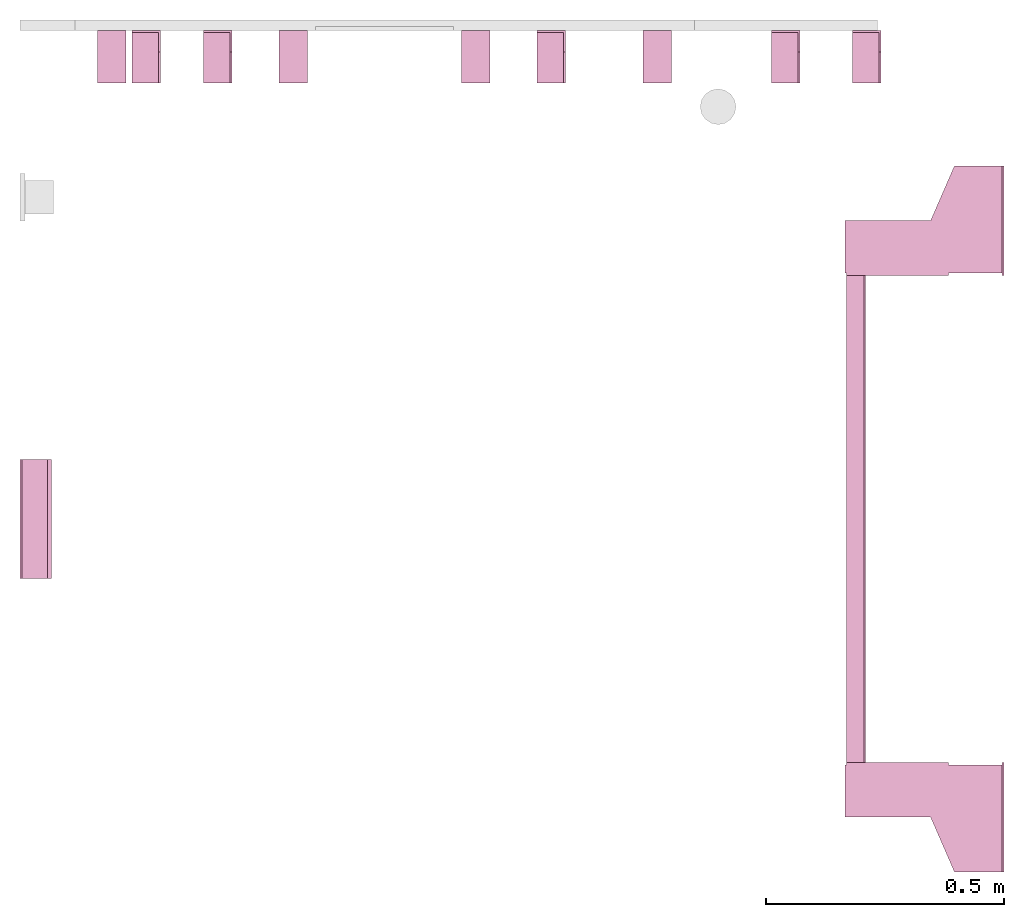
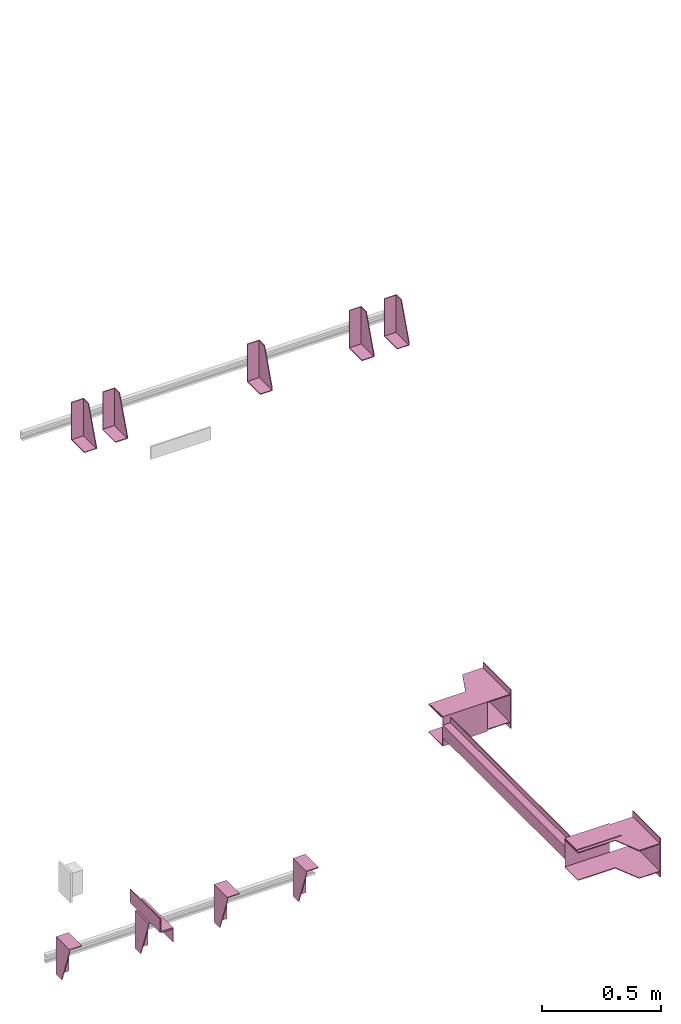
# One storey, part 3 of 3: 11 transport elements.
"""IFC4 building model written with IfcOpenShell, lengths in millimetres."""

from ifc_helpers import new_model, entity, si_unit, converted_unit, frame, origin_with_axes, place, context, subcontext, project, spatial, faceted_brep, element, save


model = new_model("IFC4")

# Units and contexts
context_of_model = context(None, 3, precision=0.01, world=origin_with_axes())
sub_context_1 = subcontext(context_of_model, None, None, "MODEL_VIEW")
sub_context_2 = subcontext(context_of_model, None, None, "MODEL_VIEW")
sub_context_3 = subcontext(context_of_model, None, None, "MODEL_VIEW")
sub_context_4 = subcontext(context_of_model, None, None, "MODEL_VIEW")
sub_context_5 = subcontext(context_of_model, None, None, "MODEL_VIEW")
sub_context_6 = subcontext(context_of_model, None, None, "MODEL_VIEW")
sub_context_7 = subcontext(context_of_model, None, None, "MODEL_VIEW")
sub_context_8 = subcontext(context_of_model, None, None, "MODEL_VIEW")
sub_context_9 = subcontext(context_of_model, None, None, "MODEL_VIEW")
sub_context_10 = subcontext(context_of_model, None, None, "MODEL_VIEW")
sub_context_11 = subcontext(context_of_model, None, None, "MODEL_VIEW")
ifc_project = project(units=[converted_unit("PLANEANGLEUNIT", "degree", entity("IfcPlaneAngleMeasure", 0.017453292519943), si_unit("PLANEANGLEUNIT", "RADIAN"), dimensions=[0, 0, 0, 0, 0, 0, 0]), si_unit("LENGTHUNIT", "METRE", prefix="MILLI"), si_unit("MASSUNIT", "GRAM", prefix="KILO"), converted_unit("TIMEUNIT", "year", entity("IfcTimeMeasure", 31557600.0), si_unit("TIMEUNIT", "SECOND"), dimensions=[0, 0, 1, 0, 0, 0, 0]), si_unit("THERMODYNAMICTEMPERATUREUNIT", "DEGREE_CELSIUS"), si_unit("AREAUNIT", "SQUARE_METRE"), si_unit("FORCEUNIT", "NEWTON"), si_unit("VOLUMEUNIT", "CUBIC_METRE"), si_unit("PRESSUREUNIT", "PASCAL"), si_unit("SOLIDANGLEUNIT", "STERADIAN")], contexts=[context_of_model])

# Site, building, storey
site = spatial("IfcSite", under=ifc_project)
building = spatial("IfcBuilding", under=site, Name="Document")
placement = place(None, origin_with_axes())
storey_placement = place(placement, frame((0.0, 0.0, -15980.0), z_axis=(0.0, 0.0, 1.0), x_axis=(1.0, 0.0, 0.0)))
storey = spatial("IfcBuildingStorey", under=building, at=storey_placement, Name="P5", Elevation=-15980.0)

# Transport elements
transport_element_1_placement = place(storey_placement, frame((2065.0, 1025.0, 780.0), z_axis=(0.0, 0.0, 1.0), x_axis=(0.0, 1.0, 0.0)))
element("IfcTransportElement", 1, at=transport_element_1_placement, inside=storey, PredefinedType="ELEVATOR", context=sub_context_1, shape_type="Brep", body=[
    faceted_brep([(-511.0, 291.0, -32.5), (-511.0, 294.0, -32.5), (-511.0, 294.0, -59.5), (-511.0, 291.0, -59.5), (511.0, 291.0, -32.5), (511.0, 291.0, -59.5), (511.0, 294.0, -59.5), (511.0, 294.0, -32.5)], [[[0, 1, 2, 3]], [[4, 5, 6, 7]], [[0, 3, 5, 4]], [[3, 2, 6, 5]], [[2, 1, 7, 6]], [[1, 0, 4, 7]]]),
    faceted_brep([(-611.0, 331.0, -72.5), (-514.0, 331.0, -72.5), (-514.0, 331.0, 72.5), (-611.0, 331.0, 72.5), (-611.0, 331.0, 75.5), (-511.0, 331.0, 75.5), (-511.0, 331.0, -75.5), (-611.0, 331.0, -75.5), (-511.0, 116.0, -75.5), (-511.0, 116.0, 75.5), (-611.0, 116.0, 75.5), (-611.0, 116.0, 72.5), (-514.0, 116.0, 72.5), (-514.0, 116.0, -72.5), (-611.0, 116.0, -72.5), (-611.0, 116.0, -75.5)], [[[0, 1, 2, 3, 4, 5, 6, 7]], [[8, 9, 10, 11, 12, 13, 14, 15]], [[15, 14, 0, 7]], [[13, 12, 2, 1]], [[5, 9, 8, 6]], [[11, 10, 4, 3]], [[6, 8, 15, 7]], [[14, 13, 1, 0]], [[2, 12, 11, 3]], [[10, 9, 5, 4]]]),
    faceted_brep([(-511.0, 291.0, 59.5), (-511.0, 294.0, 59.5), (-511.0, 294.0, 32.5), (-511.0, 291.0, 32.5), (511.0, 291.0, 59.5), (511.0, 291.0, 32.5), (511.0, 294.0, 32.5), (511.0, 294.0, 59.5)], [[[0, 1, 2, 3]], [[4, 5, 6, 7]], [[0, 3, 5, 4]], [[3, 2, 6, 5]], [[2, 1, 7, 6]], [[1, 0, 4, 7]]]),
    faceted_brep([(511.0, 331.0, 75.5), (611.0, 331.0, 75.5), (611.0, 331.0, 72.5), (514.0, 331.0, 72.5), (514.0, 331.0, -72.5), (611.0, 331.0, -72.5), (611.0, 331.0, -75.5), (511.0, 331.0, -75.5), (511.0, 116.0, -75.5), (611.0, 116.0, -75.5), (611.0, 116.0, -72.5), (514.0, 116.0, -72.5), (514.0, 116.0, 72.5), (611.0, 116.0, 72.5), (611.0, 116.0, 75.5), (511.0, 116.0, 75.5)], [[[0, 1, 2, 3, 4, 5, 6, 7]], [[8, 9, 10, 11, 12, 13, 14, 15]], [[8, 15, 0, 7]], [[3, 12, 11, 4]], [[5, 10, 9, 6]], [[1, 14, 13, 2]], [[6, 9, 8, 7]], [[11, 10, 5, 4]], [[15, 14, 1, 0]], [[2, 13, 12, 3]]]),
    faceted_brep([(-511.0, 331.0, 32.5), (511.0, 331.0, 32.5), (511.0, 331.0, -32.5), (-511.0, 331.0, -32.5), (511.0, 328.0, -29.5), (511.0, 328.0, 29.5), (-511.0, 328.0, 29.5), (-511.0, 328.0, -29.5), (511.0, 291.0, -32.5), (511.0, 291.0, -29.5), (-511.0, 291.0, -29.5), (-511.0, 291.0, -32.5), (511.0, 291.0, 29.5), (511.0, 291.0, 32.5), (-511.0, 291.0, 32.5), (-511.0, 291.0, 29.5)], [[[0, 1, 2, 3]], [[4, 5, 6, 7]], [[8, 9, 10, 11]], [[12, 13, 14, 15]], [[11, 10, 7, 6, 15, 14, 0, 3]], [[2, 1, 13, 12, 5, 4, 9, 8]], [[2, 8, 11, 3]], [[10, 9, 4, 7]], [[14, 13, 1, 0]], [[5, 12, 15, 6]]]),
    faceted_brep([(516.0, 334.0, -68.5), (626.0, 334.0, -68.5), (626.0, 334.0, -72.5), (516.0, 334.0, -72.5), (741.0, 4.0, -72.5), (741.0, 4.0, -68.5), (516.0, 4.0, -68.5), (516.0, 4.0, -72.5), (626.0, 154.0, -68.5), (741.0, 104.0, -68.5), (741.0, 104.0, -72.5), (626.0, 154.0, -72.5)], [[[0, 1, 2, 3]], [[4, 5, 6, 7]], [[8, 9, 10, 11]], [[7, 6, 0, 3]], [[1, 8, 11, 2]], [[9, 5, 4, 10]], [[2, 11, 10, 4, 7, 3]], [[6, 5, 9, 8, 1, 0]]]),
    faceted_brep([(-626.0, 334.0, -68.5), (-516.0, 334.0, -68.5), (-516.0, 334.0, -72.5), (-626.0, 334.0, -72.5), (-516.0, 4.0, -72.5), (-516.0, 4.0, -68.5), (-741.0, 4.0, -68.5), (-741.0, 4.0, -72.5), (-741.0, 104.0, -68.5), (-626.0, 154.0, -68.5), (-626.0, 154.0, -72.5), (-741.0, 104.0, -72.5)], [[[0, 1, 2, 3]], [[4, 5, 6, 7]], [[8, 9, 10, 11]], [[10, 9, 0, 3]], [[1, 5, 4, 2]], [[7, 6, 8, 11]], [[2, 4, 7, 11, 10, 3]], [[9, 8, 6, 5, 1, 0]]]),
    faceted_brep([(516.0, 334.0, 72.5), (626.0, 334.0, 72.5), (626.0, 334.0, 68.5), (516.0, 334.0, 68.5), (741.0, 4.0, 68.5), (741.0, 4.0, 72.5), (516.0, 4.0, 72.5), (516.0, 4.0, 68.5), (626.0, 154.0, 72.5), (741.0, 104.0, 72.5), (741.0, 104.0, 68.5), (626.0, 154.0, 68.5)], [[[0, 1, 2, 3]], [[4, 5, 6, 7]], [[8, 9, 10, 11]], [[7, 6, 0, 3]], [[1, 8, 11, 2]], [[9, 5, 4, 10]], [[2, 11, 10, 4, 7, 3]], [[6, 5, 9, 8, 1, 0]]]),
    faceted_brep([(-626.0, 334.0, 72.5), (-516.0, 334.0, 72.5), (-516.0, 334.0, 68.5), (-626.0, 334.0, 68.5), (-516.0, 4.0, 68.5), (-516.0, 4.0, 72.5), (-741.0, 4.0, 72.5), (-741.0, 4.0, 68.5), (-741.0, 104.0, 72.5), (-626.0, 154.0, 72.5), (-626.0, 154.0, 68.5), (-741.0, 104.0, 68.5)], [[[0, 1, 2, 3]], [[4, 5, 6, 7]], [[8, 9, 10, 11]], [[10, 9, 0, 3]], [[1, 5, 4, 2]], [[7, 6, 8, 11]], [[2, 4, 7, 11, 10, 3]], [[9, 8, 6, 5, 1, 0]]]),
    faceted_brep([(741.0, 0.0, -100.0), (741.0, 0.0, 100.0), (511.0, 0.0, 100.0), (511.0, 0.0, -100.0), (741.0, 4.0, -100.0), (511.0, 4.0, -100.0), (511.0, 4.0, 100.0), (741.0, 4.0, 100.0)], [[[0, 1, 2, 3]], [[4, 5, 6, 7]], [[0, 3, 5, 4]], [[3, 2, 6, 5]], [[2, 1, 7, 6]], [[1, 0, 4, 7]]]),
    faceted_brep([(-511.0, 0.0, -100.0), (-511.0, 0.0, 100.0), (-741.0, 0.0, 100.0), (-741.0, 0.0, -100.0), (-511.0, 4.0, -100.0), (-741.0, 4.0, -100.0), (-741.0, 4.0, 100.0), (-511.0, 4.0, 100.0)], [[[0, 1, 2, 3]], [[4, 5, 6, 7]], [[0, 3, 5, 4]], [[3, 2, 6, 5]], [[2, 1, 7, 6]], [[1, 0, 4, 7]]]),
])
transport_element_2_placement = place(storey_placement, frame((1777.0, 2050.0, 2580.0), z_axis=(0.0, 0.0, 1.0), x_axis=(-1.0, 0.0, 0.0)))
element("IfcTransportElement", 2, at=transport_element_2_placement, inside=storey, PredefinedType="ELEVATOR", context=sub_context_2, shape_type="Brep", body=[
    faceted_brep([(30.0, 110.0, -93.0), (30.0, 4.0, -93.0), (30.0, 4.0, 97.0), (30.0, 0.0, 97.0), (30.0, 0.0, -97.0), (30.0, 110.0, -97.0), (-30.0, 0.0, -97.0), (-30.0, 0.0, 97.0), (-30.0, 4.0, 97.0), (-30.0, 4.0, -93.0), (-30.0, 110.0, -93.0), (-30.0, 110.0, -97.0)], [[[0, 1, 2, 3, 4, 5]], [[6, 7, 8, 9, 10, 11]], [[11, 10, 0, 5]], [[9, 8, 2, 1]], [[3, 7, 6, 4]], [[4, 6, 11, 5]], [[10, 9, 1, 0]], [[8, 7, 3, 2]]]),
    faceted_brep([(-30.0, 4.0, -93.0), (-30.0, 4.0, 97.0), (-30.0, 45.0, 97.0), (-30.0, 110.0, -82.0), (-30.0, 110.0, -93.0), (-26.0, 4.0, -93.0), (-26.0, 110.0, -93.0), (-26.0, 110.0, -82.0), (-26.0, 45.0, 97.0), (-26.0, 4.0, 97.0)], [[[0, 1, 2, 3, 4]], [[5, 6, 7, 8, 9]], [[5, 0, 4, 6]], [[6, 4, 3, 7]], [[7, 3, 2, 8]], [[8, 2, 1, 9]], [[9, 1, 0, 5]]]),
])
transport_element_3_placement = place(storey_placement, frame((1607.0, 2050.0, 2580.0), z_axis=(0.0, 0.0, 1.0), x_axis=(-1.0, 0.0, 0.0)))
element("IfcTransportElement", 3, at=transport_element_3_placement, inside=storey, PredefinedType="ELEVATOR", context=sub_context_3, shape_type="Brep", body=[
    faceted_brep([(30.0, 110.0, -93.0), (30.0, 4.0, -93.0), (30.0, 4.0, 97.0), (30.0, 0.0, 97.0), (30.0, 0.0, -97.0), (30.0, 110.0, -97.0), (-30.0, 0.0, -97.0), (-30.0, 0.0, 97.0), (-30.0, 4.0, 97.0), (-30.0, 4.0, -93.0), (-30.0, 110.0, -93.0), (-30.0, 110.0, -97.0)], [[[0, 1, 2, 3, 4, 5]], [[6, 7, 8, 9, 10, 11]], [[11, 10, 0, 5]], [[9, 8, 2, 1]], [[3, 7, 6, 4]], [[4, 6, 11, 5]], [[10, 9, 1, 0]], [[8, 7, 3, 2]]]),
    faceted_brep([(-30.0, 4.0, -93.0), (-30.0, 4.0, 97.0), (-30.0, 45.0, 97.0), (-30.0, 110.0, -82.0), (-30.0, 110.0, -93.0), (-26.0, 4.0, -93.0), (-26.0, 110.0, -93.0), (-26.0, 110.0, -82.0), (-26.0, 45.0, 97.0), (-26.0, 4.0, 97.0)], [[[0, 1, 2, 3, 4]], [[5, 6, 7, 8, 9]], [[5, 0, 4, 6]], [[6, 4, 3, 7]], [[7, 3, 2, 8]], [[8, 2, 1, 9]], [[9, 1, 0, 5]]]),
])
transport_element_4_placement = place(storey_placement, frame((1115.0, 2050.0, 2580.0), z_axis=(0.0, 0.0, 1.0), x_axis=(-1.0, 0.0, 0.0)))
element("IfcTransportElement", 4, at=transport_element_4_placement, inside=storey, PredefinedType="ELEVATOR", context=sub_context_4, shape_type="Brep", body=[
    faceted_brep([(30.0, 110.0, -93.0), (30.0, 4.0, -93.0), (30.0, 4.0, 97.0), (30.0, 0.0, 97.0), (30.0, 0.0, -97.0), (30.0, 110.0, -97.0), (-30.0, 0.0, -97.0), (-30.0, 0.0, 97.0), (-30.0, 4.0, 97.0), (-30.0, 4.0, -93.0), (-30.0, 110.0, -93.0), (-30.0, 110.0, -97.0)], [[[0, 1, 2, 3, 4, 5]], [[6, 7, 8, 9, 10, 11]], [[11, 10, 0, 5]], [[9, 8, 2, 1]], [[3, 7, 6, 4]], [[4, 6, 11, 5]], [[10, 9, 1, 0]], [[8, 7, 3, 2]]]),
    faceted_brep([(-30.0, 4.0, -93.0), (-30.0, 4.0, 97.0), (-30.0, 45.0, 97.0), (-30.0, 110.0, -82.0), (-30.0, 110.0, -93.0), (-26.0, 4.0, -93.0), (-26.0, 110.0, -93.0), (-26.0, 110.0, -82.0), (-26.0, 45.0, 97.0), (-26.0, 4.0, 97.0)], [[[0, 1, 2, 3, 4]], [[5, 6, 7, 8, 9]], [[5, 0, 4, 6]], [[6, 4, 3, 7]], [[7, 3, 2, 8]], [[8, 2, 1, 9]], [[9, 1, 0, 5]]]),
])
transport_element_5_placement = place(storey_placement, frame((415.0, 2050.0, 2580.0), z_axis=(0.0, 0.0, 1.0), x_axis=(-1.0, 0.0, 0.0)))
element("IfcTransportElement", 5, at=transport_element_5_placement, inside=storey, PredefinedType="ELEVATOR", context=sub_context_5, shape_type="Brep", body=[
    faceted_brep([(30.0, 110.0, -93.0), (30.0, 4.0, -93.0), (30.0, 4.0, 97.0), (30.0, 0.0, 97.0), (30.0, 0.0, -97.0), (30.0, 110.0, -97.0), (-30.0, 0.0, -97.0), (-30.0, 0.0, 97.0), (-30.0, 4.0, 97.0), (-30.0, 4.0, -93.0), (-30.0, 110.0, -93.0), (-30.0, 110.0, -97.0)], [[[0, 1, 2, 3, 4, 5]], [[6, 7, 8, 9, 10, 11]], [[11, 10, 0, 5]], [[9, 8, 2, 1]], [[3, 7, 6, 4]], [[4, 6, 11, 5]], [[10, 9, 1, 0]], [[8, 7, 3, 2]]]),
    faceted_brep([(-30.0, 4.0, -93.0), (-30.0, 4.0, 97.0), (-30.0, 45.0, 97.0), (-30.0, 110.0, -82.0), (-30.0, 110.0, -93.0), (-26.0, 4.0, -93.0), (-26.0, 110.0, -93.0), (-26.0, 110.0, -82.0), (-26.0, 45.0, 97.0), (-26.0, 4.0, 97.0)], [[[0, 1, 2, 3, 4]], [[5, 6, 7, 8, 9]], [[5, 0, 4, 6]], [[6, 4, 3, 7]], [[7, 3, 2, 8]], [[8, 2, 1, 9]], [[9, 1, 0, 5]]]),
])
transport_element_6_placement = place(storey_placement, frame((265.0, 2050.0, 2580.0), z_axis=(0.0, 0.0, 1.0), x_axis=(-1.0, 0.0, 0.0)))
element("IfcTransportElement", 6, at=transport_element_6_placement, inside=storey, PredefinedType="ELEVATOR", context=sub_context_6, shape_type="Brep", body=[
    faceted_brep([(30.0, 110.0, -93.0), (30.0, 4.0, -93.0), (30.0, 4.0, 97.0), (30.0, 0.0, 97.0), (30.0, 0.0, -97.0), (30.0, 110.0, -97.0), (-30.0, 0.0, -97.0), (-30.0, 0.0, 97.0), (-30.0, 4.0, 97.0), (-30.0, 4.0, -93.0), (-30.0, 110.0, -93.0), (-30.0, 110.0, -97.0)], [[[0, 1, 2, 3, 4, 5]], [[6, 7, 8, 9, 10, 11]], [[11, 10, 0, 5]], [[9, 8, 2, 1]], [[3, 7, 6, 4]], [[4, 6, 11, 5]], [[10, 9, 1, 0]], [[8, 7, 3, 2]]]),
    faceted_brep([(-30.0, 4.0, -93.0), (-30.0, 4.0, 97.0), (-30.0, 45.0, 97.0), (-30.0, 110.0, -82.0), (-30.0, 110.0, -93.0), (-26.0, 4.0, -93.0), (-26.0, 110.0, -93.0), (-26.0, 110.0, -82.0), (-26.0, 45.0, 97.0), (-26.0, 4.0, 97.0)], [[[0, 1, 2, 3, 4]], [[5, 6, 7, 8, 9]], [[5, 0, 4, 6]], [[6, 4, 3, 7]], [[7, 3, 2, 8]], [[8, 2, 1, 9]], [[9, 1, 0, 5]]]),
])
transport_element_7_placement = place(storey_placement, frame((192.5, 2050.0, -30.0), z_axis=(0.0, 0.0, -1.0), x_axis=(1.0, 0.0, 0.0)))
element("IfcTransportElement", 7, at=transport_element_7_placement, inside=storey, PredefinedType="ELEVATOR", context=sub_context_7, shape_type="Brep", body=[
    faceted_brep([(-30.0, 4.0, 4.0), (-30.0, 4.0, 194.0), (-30.0, 45.0, 194.0), (-30.0, 110.0, 15.0), (-30.0, 110.0, 4.0), (-26.0, 4.0, 4.0), (-26.0, 110.0, 4.0), (-26.0, 110.0, 15.0), (-26.0, 45.0, 194.0), (-26.0, 4.0, 194.0)], [[[0, 1, 2, 3, 4]], [[5, 6, 7, 8, 9]], [[5, 0, 4, 6]], [[6, 4, 3, 7]], [[7, 3, 2, 8]], [[8, 2, 1, 9]], [[9, 1, 0, 5]]]),
    faceted_brep([(-30.0, 4.0, 4.0), (-30.0, 110.0, 4.0), (-30.0, 110.0, 0.0), (-30.0, 0.0, 0.0), (-30.0, 0.0, 194.0), (-30.0, 4.0, 194.0), (30.0, 0.0, 194.0), (30.0, 0.0, 0.0), (30.0, 110.0, 0.0), (30.0, 110.0, 4.0), (30.0, 4.0, 4.0), (30.0, 4.0, 194.0)], [[[0, 1, 2, 3, 4, 5]], [[6, 7, 8, 9, 10, 11]], [[11, 10, 0, 5]], [[3, 7, 6, 4]], [[9, 8, 2, 1]], [[4, 6, 11, 5]], [[0, 10, 9, 1]], [[8, 7, 3, 2]]]),
])
transport_element_8_placement = place(storey_placement, frame((573.84, 2050.0, -30.0), z_axis=(0.0, 0.0, -1.0), x_axis=(1.0, 0.0, 0.0)))
element("IfcTransportElement", 8, at=transport_element_8_placement, inside=storey, PredefinedType="ELEVATOR", context=sub_context_8, shape_type="Brep", body=[
    faceted_brep([(-29.999973144531282, 4.0, 4.0), (-29.999973144531282, 4.0, 194.0), (-29.999973144531282, 45.0, 194.0), (-29.999973144531282, 110.0, 15.0), (-29.999973144531282, 110.0, 4.0), (-25.999973144531282, 4.0, 4.0), (-25.999973144531282, 110.0, 4.0), (-25.999973144531282, 110.0, 15.0), (-25.999973144531282, 45.0, 194.0), (-25.999973144531282, 4.0, 194.0)], [[[0, 1, 2, 3, 4]], [[5, 6, 7, 8, 9]], [[5, 0, 4, 6]], [[6, 4, 3, 7]], [[7, 3, 2, 8]], [[8, 2, 1, 9]], [[9, 1, 0, 5]]]),
    faceted_brep([(-29.999973144531282, 4.0, 4.0), (-29.999973144531282, 110.0, 4.0), (-29.999973144531282, 110.0, 0.0), (-29.999973144531282, 0.0, 0.0), (-29.999973144531282, 0.0, 194.0), (-29.999973144531282, 4.0, 194.0), (30.000026855468718, 0.0, 194.0), (30.000026855468718, 0.0, 0.0), (30.000026855468718, 110.0, 0.0), (30.000026855468718, 110.0, 4.0), (30.000026855468718, 4.0, 4.0), (30.000026855468718, 4.0, 194.0)], [[[0, 1, 2, 3, 4, 5]], [[6, 7, 8, 9, 10, 11]], [[11, 10, 0, 5]], [[3, 7, 6, 4]], [[9, 8, 2, 1]], [[4, 6, 11, 5]], [[0, 10, 9, 1]], [[8, 7, 3, 2]]]),
])
transport_element_9_placement = place(storey_placement, frame((956.16, 2050.0, -30.0), z_axis=(0.0, 0.0, -1.0), x_axis=(1.0, 0.0, 0.0)))
element("IfcTransportElement", 9, at=transport_element_9_placement, inside=storey, PredefinedType="ELEVATOR", context=sub_context_9, shape_type="Brep", body=[
    faceted_brep([(-30.000026855468718, 4.0, 4.0), (-30.000026855468718, 110.0, 4.0), (-30.000026855468718, 110.0, 0.0), (-30.000026855468718, 0.0, 0.0), (-30.000026855468718, 0.0, 194.0), (-30.000026855468718, 4.0, 194.0), (29.999973144531282, 0.0, 194.0), (29.999973144531282, 0.0, 0.0), (29.999973144531282, 110.0, 0.0), (29.999973144531282, 110.0, 4.0), (29.999973144531282, 4.0, 4.0), (29.999973144531282, 4.0, 194.0)], [[[0, 1, 2, 3, 4, 5]], [[6, 7, 8, 9, 10, 11]], [[11, 10, 0, 5]], [[3, 7, 6, 4]], [[9, 8, 2, 1]], [[4, 6, 11, 5]], [[0, 10, 9, 1]], [[8, 7, 3, 2]]]),
    faceted_brep([(-30.000026855468718, 4.0, 4.0), (-30.000026855468718, 4.0, 194.0), (-30.000026855468718, 45.0, 194.0), (-30.000026855468718, 110.0, 15.0), (-30.000026855468718, 110.0, 4.0), (-26.000026855468718, 4.0, 4.0), (-26.000026855468718, 110.0, 4.0), (-26.000026855468718, 110.0, 15.0), (-26.000026855468718, 45.0, 194.0), (-26.000026855468718, 4.0, 194.0)], [[[0, 1, 2, 3, 4]], [[5, 6, 7, 8, 9]], [[5, 0, 4, 6]], [[6, 4, 3, 7]], [[7, 3, 2, 8]], [[8, 2, 1, 9]], [[9, 1, 0, 5]]]),
])
transport_element_10_placement = place(storey_placement, frame((1337.5, 2050.0, -30.0), z_axis=(0.0, 0.0, -1.0), x_axis=(1.0, 0.0, 0.0)))
element("IfcTransportElement", 10, at=transport_element_10_placement, inside=storey, PredefinedType="ELEVATOR", context=sub_context_10, shape_type="Brep", body=[
    faceted_brep([(-30.0, 4.0, 4.0), (-30.0, 110.0, 4.0), (-30.0, 110.0, 0.0), (-30.0, 0.0, 0.0), (-30.0, 0.0, 194.0), (-30.0, 4.0, 194.0), (30.0, 0.0, 194.0), (30.0, 0.0, 0.0), (30.0, 110.0, 0.0), (30.0, 110.0, 4.0), (30.0, 4.0, 4.0), (30.0, 4.0, 194.0)], [[[0, 1, 2, 3, 4, 5]], [[6, 7, 8, 9, 10, 11]], [[11, 10, 0, 5]], [[3, 7, 6, 4]], [[9, 8, 2, 1]], [[4, 6, 11, 5]], [[0, 10, 9, 1]], [[8, 7, 3, 2]]]),
    faceted_brep([(-30.0, 4.0, 4.0), (-30.0, 4.0, 194.0), (-30.0, 45.0, 194.0), (-30.0, 110.0, 15.0), (-30.0, 110.0, 4.0), (-26.0, 4.0, 4.0), (-26.0, 110.0, 4.0), (-26.0, 110.0, 15.0), (-26.0, 45.0, 194.0), (-26.0, 4.0, 194.0)], [[[0, 1, 2, 3, 4]], [[5, 6, 7, 8, 9]], [[5, 0, 4, 6]], [[6, 4, 3, 7]], [[7, 3, 2, 8]], [[8, 2, 1, 9]], [[9, 1, 0, 5]]]),
])
transport_element_11_placement = place(storey_placement, frame((0.0, 1025.0, 780.0), z_axis=(0.0, 0.0, 1.0), x_axis=(0.0, -1.0, 0.0)))
element("IfcTransportElement", 11, at=transport_element_11_placement, inside=storey, PredefinedType="ELEVATOR", context=sub_context_11, shape_type="Brep", body=[
    faceted_brep([(125.0, 0.0, 35.0), (-125.0, 0.0, 35.0), (-125.0, 0.0, -35.0), (125.0, 0.0, -35.0), (-125.0, 4.0, -31.0), (-125.0, 4.0, 35.0), (125.0, 4.0, 35.0), (125.0, 4.0, -31.0), (-125.0, 58.0, -35.0), (-125.0, 58.0, -31.0), (125.0, 58.0, -31.0), (125.0, 58.0, -35.0)], [[[0, 1, 2, 3]], [[4, 5, 6, 7]], [[8, 9, 10, 11]], [[11, 10, 7, 6, 0, 3]], [[2, 1, 5, 4, 9, 8]], [[2, 8, 11, 3]], [[10, 9, 4, 7]], [[6, 5, 1, 0]]]),
    faceted_brep([(125.0, 8.0, -35.0), (-125.0, 8.0, -35.0), (-125.0, 8.0, -39.0), (125.0, 8.0, -39.0), (125.0, 62.0, -39.0), (-125.0, 62.0, -39.0), (-125.0, 62.0, -105.0), (125.0, 62.0, -105.0), (-125.0, 66.0, -105.0), (-125.0, 66.0, -35.0), (125.0, 66.0, -35.0), (125.0, 66.0, -105.0)], [[[0, 1, 2, 3]], [[4, 5, 6, 7]], [[8, 9, 10, 11]], [[4, 7, 11, 10, 0, 3]], [[1, 9, 8, 6, 5, 2]], [[2, 5, 4, 3]], [[10, 9, 1, 0]], [[6, 8, 11, 7]]]),
])

save(model, "model.ifc")
